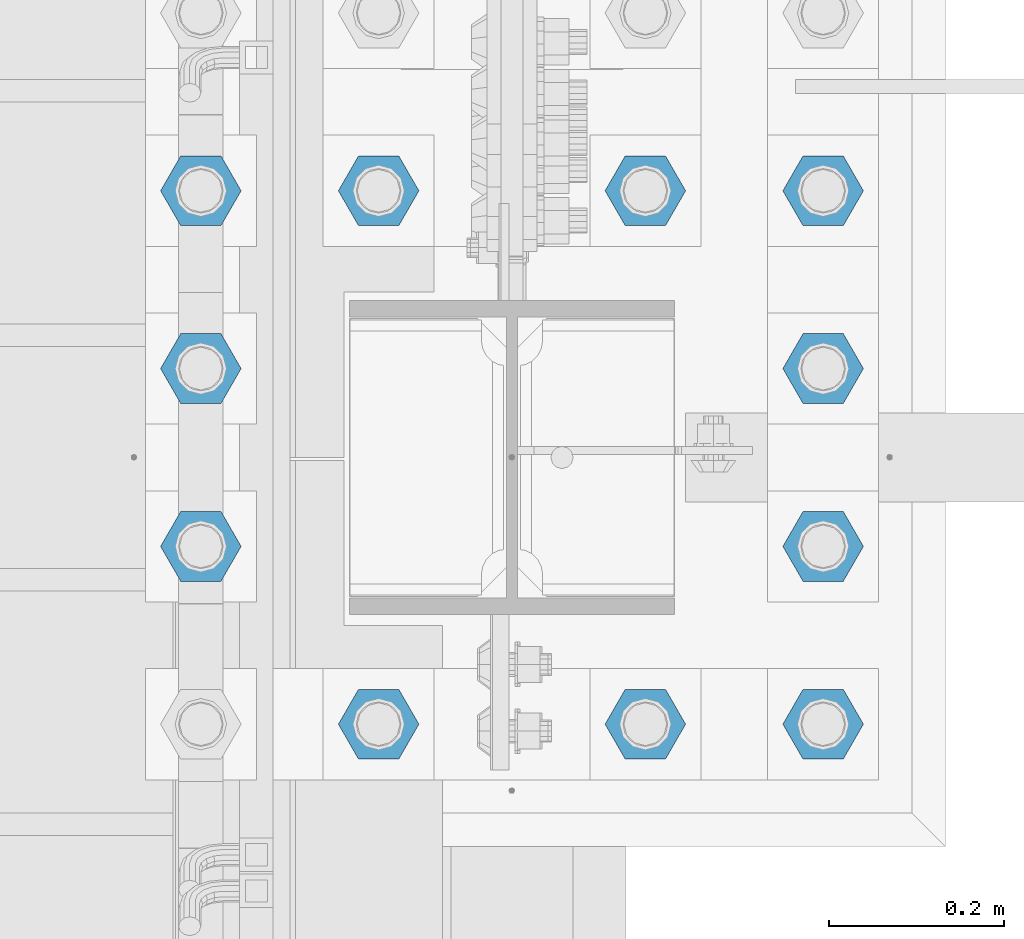
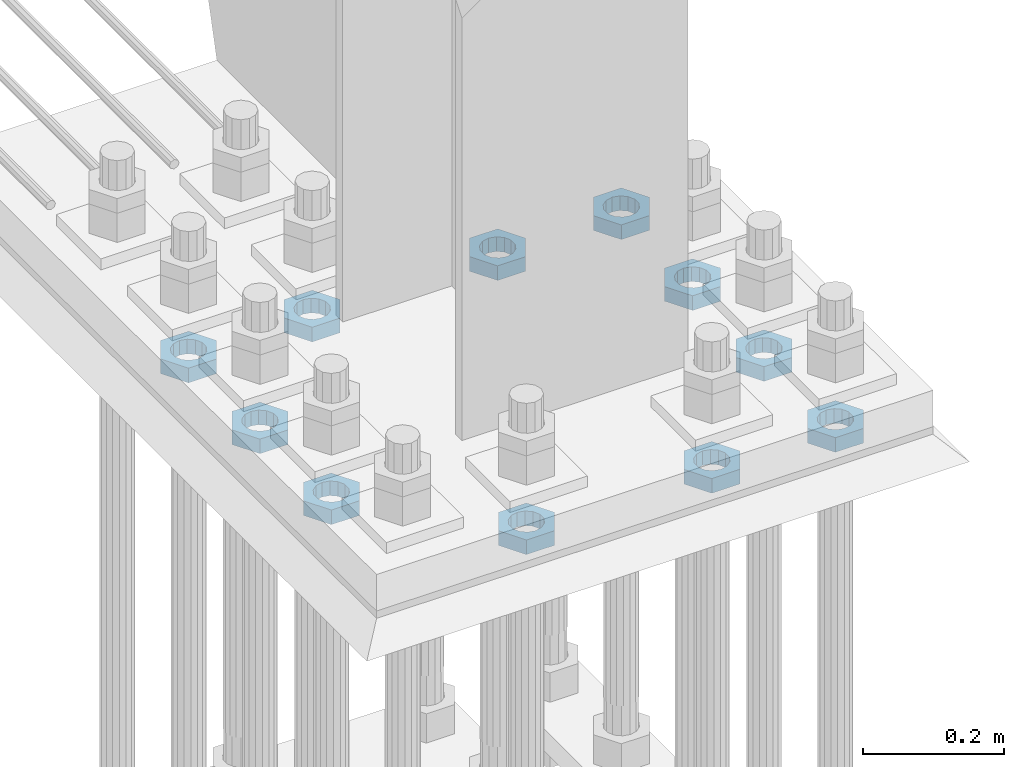
# One storey, part 2090 of 3843: 11 beams, 1 element without a shape of its own.
"""IFC2X3 building model written with IfcOpenShell, lengths in millimetres."""

from ifc_helpers import new_model, si_unit, frame, origin_with_axes, place, context, subcontext, project, spatial, faceted_brep, material, type_object, element, aggregate, save


model = new_model("IFC2X3")

# Units and contexts
model_context = context("Model", 3, precision=1e-05, world=origin_with_axes())
body_context = subcontext(model_context, "Body", "Model", "MODEL_VIEW")
ifc_project = project(units=[si_unit("LENGTHUNIT", "METRE", prefix="MILLI"), si_unit("AREAUNIT", "SQUARE_METRE"), si_unit("VOLUMEUNIT", "CUBIC_METRE"), si_unit("MASSUNIT", "GRAM", prefix="KILO"), si_unit("TIMEUNIT", "SECOND"), si_unit("PLANEANGLEUNIT", "RADIAN"), si_unit("SOLIDANGLEUNIT", "STERADIAN"), si_unit("THERMODYNAMICTEMPERATUREUNIT", "DEGREE_CELSIUS"), si_unit("LUMINOUSINTENSITYUNIT", "LUMEN")], contexts=[model_context])

# Site, building, storey
site_placement = place(None, origin_with_axes())
site = spatial("IfcSite", under=ifc_project, at=site_placement, CompositionType="ELEMENT")
building_placement = place(site_placement, origin_with_axes())
building = spatial("IfcBuilding", under=site, at=building_placement, Name="Undefined", CompositionType="ELEMENT")
storey_placement = place(building_placement, origin_with_axes())
storey = spatial("IfcBuildingStorey", under=building, at=storey_placement, Name="Undefined", CompositionType="ELEMENT", Elevation=0.0)

# Assembly, beams
assembly_placement = place(storey_placement, origin_with_axes())
assembly = element("IfcElementAssembly", 1, at=assembly_placement, inside=storey, Name="TEMPLATE", AssemblyPlace="NOTDEFINED", PredefinedType="RIGID_FRAME")
ifc_material = material(Name="STEEL/A572-50")
beam_type = type_object("IfcBeamType", Name="2_HALF_NUT", PredefinedType="NOTDEFINED")
beam_1_placement = place(assembly_placement, frame((55575.2, 20205.7, 29603.7), z_axis=(0.0, -1.0, 0.0), x_axis=(0.0, 0.0, -1.0)))
beam_1 = element("IfcBeam", 2, at=beam_1_placement, type_object=beam_type, material=ifc_material, Name="NUT", ObjectType="2_HALF_NUT", context=body_context, shape_type="Brep", body=[
    faceted_brep([(0.0, -46.0369987487793, 0.0), (0.0, -23.0184993743896, -39.869213104248), (25.4000000000015, -23.0184993743896, -39.869213104248), (25.4000000000015, -46.0369987487793, 0.0), (0.0, 23.0184993743896, -39.869213104248), (25.4000000000015, 23.0184993743896, -39.869213104248), (0.0, 46.0369987487793, 0.0), (25.4000000000015, 46.0369987487793, 0.0), (0.0, 23.0184993743896, 39.869213104248), (25.4000000000015, 23.0184993743896, 39.869213104248), (0.0, -23.0184993743896, 39.869213104248), (25.4000000000015, -23.0184993743896, 39.869213104248), (0.0, 0.0, 26.1940002441406), (0.0, 11.3650617044477, 23.5999013092805), (25.4000000000015, 11.3650617044477, 23.5999013092805), (25.4000000000015, 0.0, 26.1940002441406), (0.0, 20.4791109456419, 16.3316083006721), (25.4000000000015, 20.4791109456419, 16.3316083006721), (0.0, 25.5370200498292, 5.82867859874386), (25.4000000000015, 25.5370200498292, 5.82867859874386), (0.0, 25.5370200498292, -5.82867859874386), (25.4000000000015, 25.5370200498292, -5.82867859874386), (0.0, 20.4791109456419, -16.3316083006721), (25.4000000000015, 20.4791109456419, -16.3316083006721), (0.0, 11.3650617044477, -23.5999013092805), (25.4000000000015, 11.3650617044477, -23.5999013092805), (0.0, 0.0, -26.1940002441406), (25.4000000000015, 0.0, -26.1940002441406), (0.0, -11.3650617044477, -23.5999013092805), (25.4000000000015, -11.3650617044477, -23.5999013092805), (0.0, -20.4791109456419, -16.3316083006721), (25.4000000000015, -20.4791109456419, -16.3316083006721), (0.0, -25.5370200498292, -5.82867859874386), (25.4000000000015, -25.5370200498292, -5.82867859874386), (0.0, -25.5370200498292, 5.82867859874386), (25.4000000000015, -25.5370200498292, 5.82867859874386), (0.0, -20.4791109456419, 16.3316083006721), (25.4000000000015, -20.4791109456419, 16.3316083006721), (0.0, -11.3650617044477, 23.5999013092805), (25.4000000000015, -11.3650617044477, 23.5999013092805)], [[[0, 1, 2, 3]], [[1, 4, 5, 2]], [[4, 6, 7, 5]], [[6, 8, 9, 7]], [[8, 10, 11, 9]], [[10, 0, 3, 11]], [[12, 13, 14, 15]], [[13, 16, 17, 14]], [[16, 18, 19, 17]], [[18, 20, 21, 19]], [[20, 22, 23, 21]], [[22, 24, 25, 23]], [[24, 26, 27, 25]], [[26, 28, 29, 27]], [[28, 30, 31, 29]], [[30, 32, 33, 31]], [[32, 34, 35, 33]], [[34, 36, 37, 35]], [[36, 38, 39, 37]], [[38, 12, 15, 39]], [[5, 7, 9, 11, 3, 2], [17, 19, 21, 23, 25, 27, 29, 31, 33, 35, 37, 39, 15, 14]], [[10, 8, 6, 4, 1, 0], [38, 36, 34, 32, 30, 28, 26, 24, 22, 20, 18, 16, 13, 12]]]),
])
beam_2_placement = place(assembly_placement, frame((55575.2, 20408.9, 29603.7), z_axis=(0.0, -1.0, 0.0), x_axis=(0.0, 0.0, -1.0)))
beam_2 = element("IfcBeam", 3, at=beam_2_placement, type_object=beam_type, material=ifc_material, Name="NUT", ObjectType="2_HALF_NUT", context=body_context, shape_type="Brep", body=[
    faceted_brep([(0.0, -46.0369987487793, 0.0), (0.0, -23.0184993743896, -39.869213104248), (25.4000000000015, -23.0184993743896, -39.869213104248), (25.4000000000015, -46.0369987487793, 0.0), (0.0, 23.0184993743896, -39.869213104248), (25.4000000000015, 23.0184993743896, -39.869213104248), (0.0, 46.0369987487793, 0.0), (25.4000000000015, 46.0369987487793, 0.0), (0.0, 23.0184993743896, 39.869213104248), (25.4000000000015, 23.0184993743896, 39.869213104248), (0.0, -23.0184993743896, 39.869213104248), (25.4000000000015, -23.0184993743896, 39.869213104248), (0.0, 0.0, 26.1940002441406), (0.0, 11.3650617044477, 23.5999013092805), (25.4000000000015, 11.3650617044477, 23.5999013092805), (25.4000000000015, 0.0, 26.1940002441406), (0.0, 20.4791109456419, 16.3316083006721), (25.4000000000015, 20.4791109456419, 16.3316083006721), (0.0, 25.5370200498292, 5.82867859874386), (25.4000000000015, 25.5370200498292, 5.82867859874386), (0.0, 25.5370200498292, -5.82867859874386), (25.4000000000015, 25.5370200498292, -5.82867859874386), (0.0, 20.4791109456419, -16.3316083006721), (25.4000000000015, 20.4791109456419, -16.3316083006721), (0.0, 11.3650617044477, -23.5999013092805), (25.4000000000015, 11.3650617044477, -23.5999013092805), (0.0, 0.0, -26.1940002441406), (25.4000000000015, 0.0, -26.1940002441406), (0.0, -11.3650617044477, -23.5999013092805), (25.4000000000015, -11.3650617044477, -23.5999013092805), (0.0, -20.4791109456419, -16.3316083006721), (25.4000000000015, -20.4791109456419, -16.3316083006721), (0.0, -25.5370200498292, -5.82867859874386), (25.4000000000015, -25.5370200498292, -5.82867859874386), (0.0, -25.5370200498292, 5.82867859874386), (25.4000000000015, -25.5370200498292, 5.82867859874386), (0.0, -20.4791109456419, 16.3316083006721), (25.4000000000015, -20.4791109456419, 16.3316083006721), (0.0, -11.3650617044477, 23.5999013092805), (25.4000000000015, -11.3650617044477, 23.5999013092805)], [[[0, 1, 2, 3]], [[1, 4, 5, 2]], [[4, 6, 7, 5]], [[6, 8, 9, 7]], [[8, 10, 11, 9]], [[10, 0, 3, 11]], [[12, 13, 14, 15]], [[13, 16, 17, 14]], [[16, 18, 19, 17]], [[18, 20, 21, 19]], [[20, 22, 23, 21]], [[22, 24, 25, 23]], [[24, 26, 27, 25]], [[26, 28, 29, 27]], [[28, 30, 31, 29]], [[30, 32, 33, 31]], [[32, 34, 35, 33]], [[34, 36, 37, 35]], [[36, 38, 39, 37]], [[38, 12, 15, 39]], [[5, 7, 9, 11, 3, 2], [17, 19, 21, 23, 25, 27, 29, 31, 33, 35, 37, 39, 15, 14]], [[10, 8, 6, 4, 1, 0], [38, 36, 34, 32, 30, 28, 26, 24, 22, 20, 18, 16, 13, 12]]]),
])
beam_3_placement = place(assembly_placement, frame((55778.4, 20612.1, 29603.7), z_axis=(0.0, -1.0, 0.0), x_axis=(0.0, 0.0, -1.0)))
beam_3 = element("IfcBeam", 4, at=beam_3_placement, type_object=beam_type, material=ifc_material, Name="NUT", ObjectType="2_HALF_NUT", context=body_context, shape_type="Brep", body=[
    faceted_brep([(0.0, -46.0369987487793, 0.0), (0.0, -23.0184993743896, -39.869213104248), (25.4000000000015, -23.0184993743896, -39.869213104248), (25.4000000000015, -46.0369987487793, 0.0), (0.0, 23.0184993743896, -39.869213104248), (25.4000000000015, 23.0184993743896, -39.869213104248), (0.0, 46.0369987487793, 0.0), (25.4000000000015, 46.0369987487793, 0.0), (0.0, 23.0184993743896, 39.869213104248), (25.4000000000015, 23.0184993743896, 39.869213104248), (0.0, -23.0184993743896, 39.869213104248), (25.4000000000015, -23.0184993743896, 39.869213104248), (0.0, 0.0, 26.1940002441406), (0.0, 11.3650617044477, 23.5999013092805), (25.4000000000015, 11.3650617044477, 23.5999013092805), (25.4000000000015, 0.0, 26.1940002441406), (0.0, 20.4791109456419, 16.3316083006721), (25.4000000000015, 20.4791109456419, 16.3316083006721), (0.0, 25.5370200498292, 5.82867859874386), (25.4000000000015, 25.5370200498292, 5.82867859874386), (0.0, 25.5370200498292, -5.82867859874386), (25.4000000000015, 25.5370200498292, -5.82867859874386), (0.0, 20.4791109456419, -16.3316083006721), (25.4000000000015, 20.4791109456419, -16.3316083006721), (0.0, 11.3650617044477, -23.5999013092805), (25.4000000000015, 11.3650617044477, -23.5999013092805), (0.0, 0.0, -26.1940002441406), (25.4000000000015, 0.0, -26.1940002441406), (0.0, -11.3650617044477, -23.5999013092805), (25.4000000000015, -11.3650617044477, -23.5999013092805), (0.0, -20.4791109456419, -16.3316083006721), (25.4000000000015, -20.4791109456419, -16.3316083006721), (0.0, -25.5370200498292, -5.82867859874386), (25.4000000000015, -25.5370200498292, -5.82867859874386), (0.0, -25.5370200498292, 5.82867859874386), (25.4000000000015, -25.5370200498292, 5.82867859874386), (0.0, -20.4791109456419, 16.3316083006721), (25.4000000000015, -20.4791109456419, 16.3316083006721), (0.0, -11.3650617044477, 23.5999013092805), (25.4000000000015, -11.3650617044477, 23.5999013092805)], [[[0, 1, 2, 3]], [[1, 4, 5, 2]], [[4, 6, 7, 5]], [[6, 8, 9, 7]], [[8, 10, 11, 9]], [[10, 0, 3, 11]], [[12, 13, 14, 15]], [[13, 16, 17, 14]], [[16, 18, 19, 17]], [[18, 20, 21, 19]], [[20, 22, 23, 21]], [[22, 24, 25, 23]], [[24, 26, 27, 25]], [[26, 28, 29, 27]], [[28, 30, 31, 29]], [[30, 32, 33, 31]], [[32, 34, 35, 33]], [[34, 36, 37, 35]], [[36, 38, 39, 37]], [[38, 12, 15, 39]], [[5, 7, 9, 11, 3, 2], [17, 19, 21, 23, 25, 27, 29, 31, 33, 35, 37, 39, 15, 14]], [[10, 8, 6, 4, 1, 0], [38, 36, 34, 32, 30, 28, 26, 24, 22, 20, 18, 16, 13, 12]]]),
])
beam_4_placement = place(assembly_placement, frame((55575.2, 20612.1, 29603.7), z_axis=(0.0, -1.0, 0.0), x_axis=(0.0, 0.0, -1.0)))
beam_4 = element("IfcBeam", 5, at=beam_4_placement, type_object=beam_type, material=ifc_material, Name="NUT", ObjectType="2_HALF_NUT", context=body_context, shape_type="Brep", body=[
    faceted_brep([(0.0, -46.0369987487793, 0.0), (0.0, -23.0184993743896, -39.869213104248), (25.4000000000015, -23.0184993743896, -39.869213104248), (25.4000000000015, -46.0369987487793, 0.0), (0.0, 23.0184993743896, -39.869213104248), (25.4000000000015, 23.0184993743896, -39.869213104248), (0.0, 46.0369987487793, 0.0), (25.4000000000015, 46.0369987487793, 0.0), (0.0, 23.0184993743896, 39.869213104248), (25.4000000000015, 23.0184993743896, 39.869213104248), (0.0, -23.0184993743896, 39.869213104248), (25.4000000000015, -23.0184993743896, 39.869213104248), (0.0, 0.0, 26.1940002441406), (0.0, 11.3650617044477, 23.5999013092805), (25.4000000000015, 11.3650617044477, 23.5999013092805), (25.4000000000015, 0.0, 26.1940002441406), (0.0, 20.4791109456419, 16.3316083006721), (25.4000000000015, 20.4791109456419, 16.3316083006721), (0.0, 25.5370200498292, 5.82867859874386), (25.4000000000015, 25.5370200498292, 5.82867859874386), (0.0, 25.5370200498292, -5.82867859874386), (25.4000000000015, 25.5370200498292, -5.82867859874386), (0.0, 20.4791109456419, -16.3316083006721), (25.4000000000015, 20.4791109456419, -16.3316083006721), (0.0, 11.3650617044477, -23.5999013092805), (25.4000000000015, 11.3650617044477, -23.5999013092805), (0.0, 0.0, -26.1940002441406), (25.4000000000015, 0.0, -26.1940002441406), (0.0, -11.3650617044477, -23.5999013092805), (25.4000000000015, -11.3650617044477, -23.5999013092805), (0.0, -20.4791109456419, -16.3316083006721), (25.4000000000015, -20.4791109456419, -16.3316083006721), (0.0, -25.5370200498292, -5.82867859874386), (25.4000000000015, -25.5370200498292, -5.82867859874386), (0.0, -25.5370200498292, 5.82867859874386), (25.4000000000015, -25.5370200498292, 5.82867859874386), (0.0, -20.4791109456419, 16.3316083006721), (25.4000000000015, -20.4791109456419, 16.3316083006721), (0.0, -11.3650617044477, 23.5999013092805), (25.4000000000015, -11.3650617044477, 23.5999013092805)], [[[0, 1, 2, 3]], [[1, 4, 5, 2]], [[4, 6, 7, 5]], [[6, 8, 9, 7]], [[8, 10, 11, 9]], [[10, 0, 3, 11]], [[12, 13, 14, 15]], [[13, 16, 17, 14]], [[16, 18, 19, 17]], [[18, 20, 21, 19]], [[20, 22, 23, 21]], [[22, 24, 25, 23]], [[24, 26, 27, 25]], [[26, 28, 29, 27]], [[28, 30, 31, 29]], [[30, 32, 33, 31]], [[32, 34, 35, 33]], [[34, 36, 37, 35]], [[36, 38, 39, 37]], [[38, 12, 15, 39]], [[5, 7, 9, 11, 3, 2], [17, 19, 21, 23, 25, 27, 29, 31, 33, 35, 37, 39, 15, 14]], [[10, 8, 6, 4, 1, 0], [38, 36, 34, 32, 30, 28, 26, 24, 22, 20, 18, 16, 13, 12]]]),
])
beam_5_placement = place(assembly_placement, frame((56083.2, 20612.1, 29603.7), z_axis=(0.0, 1.0, 0.0), x_axis=(0.0, 0.0, -1.0)))
beam_5 = element("IfcBeam", 6, at=beam_5_placement, type_object=beam_type, material=ifc_material, Name="NUT", ObjectType="2_HALF_NUT", context=body_context, shape_type="Brep", body=[
    faceted_brep([(0.0, -46.0369987487793, 0.0), (0.0, -23.0184993743896, -39.869213104248), (25.4000000000015, -23.0184993743896, -39.869213104248), (25.4000000000015, -46.0369987487793, 0.0), (0.0, 23.0184993743896, -39.869213104248), (25.4000000000015, 23.0184993743896, -39.869213104248), (0.0, 46.0369987487793, 0.0), (25.4000000000015, 46.0369987487793, 0.0), (0.0, 23.0184993743896, 39.869213104248), (25.4000000000015, 23.0184993743896, 39.869213104248), (0.0, -23.0184993743896, 39.869213104248), (25.4000000000015, -23.0184993743896, 39.869213104248), (0.0, 0.0, 26.1940002441406), (0.0, 11.3650617044477, 23.5999013092805), (25.4000000000015, 11.3650617044477, 23.5999013092805), (25.4000000000015, 0.0, 26.1940002441406), (0.0, 20.4791109456419, 16.3316083006721), (25.4000000000015, 20.4791109456419, 16.3316083006721), (0.0, 25.5370200498292, 5.82867859874386), (25.4000000000015, 25.5370200498292, 5.82867859874386), (0.0, 25.5370200498292, -5.82867859874386), (25.4000000000015, 25.5370200498292, -5.82867859874386), (0.0, 20.4791109456419, -16.3316083006721), (25.4000000000015, 20.4791109456419, -16.3316083006721), (0.0, 11.3650617044477, -23.5999013092805), (25.4000000000015, 11.3650617044477, -23.5999013092805), (0.0, 0.0, -26.1940002441406), (25.4000000000015, 0.0, -26.1940002441406), (0.0, -11.3650617044477, -23.5999013092805), (25.4000000000015, -11.3650617044477, -23.5999013092805), (0.0, -20.4791109456419, -16.3316083006721), (25.4000000000015, -20.4791109456419, -16.3316083006721), (0.0, -25.5370200498292, -5.82867859874386), (25.4000000000015, -25.5370200498292, -5.82867859874386), (0.0, -25.5370200498292, 5.82867859874386), (25.4000000000015, -25.5370200498292, 5.82867859874386), (0.0, -20.4791109456419, 16.3316083006721), (25.4000000000015, -20.4791109456419, 16.3316083006721), (0.0, -11.3650617044477, 23.5999013092805), (25.4000000000015, -11.3650617044477, 23.5999013092805)], [[[0, 1, 2, 3]], [[1, 4, 5, 2]], [[4, 6, 7, 5]], [[6, 8, 9, 7]], [[8, 10, 11, 9]], [[10, 0, 3, 11]], [[12, 13, 14, 15]], [[13, 16, 17, 14]], [[16, 18, 19, 17]], [[18, 20, 21, 19]], [[20, 22, 23, 21]], [[22, 24, 25, 23]], [[24, 26, 27, 25]], [[26, 28, 29, 27]], [[28, 30, 31, 29]], [[30, 32, 33, 31]], [[32, 34, 35, 33]], [[34, 36, 37, 35]], [[36, 38, 39, 37]], [[38, 12, 15, 39]], [[5, 7, 9, 11, 3, 2], [17, 19, 21, 23, 25, 27, 29, 31, 33, 35, 37, 39, 15, 14]], [[10, 8, 6, 4, 1, 0], [38, 36, 34, 32, 30, 28, 26, 24, 22, 20, 18, 16, 13, 12]]]),
])
beam_6_placement = place(assembly_placement, frame((56286.4, 20612.1, 29603.7), z_axis=(0.0, 1.0, 0.0), x_axis=(0.0, 0.0, -1.0)))
beam_6 = element("IfcBeam", 7, at=beam_6_placement, type_object=beam_type, material=ifc_material, Name="NUT", ObjectType="2_HALF_NUT", context=body_context, shape_type="Brep", body=[
    faceted_brep([(0.0, -46.0369987487793, 0.0), (0.0, -23.0184993743896, -39.869213104248), (25.4000000000015, -23.0184993743896, -39.869213104248), (25.4000000000015, -46.0369987487793, 0.0), (0.0, 23.0184993743896, -39.869213104248), (25.4000000000015, 23.0184993743896, -39.869213104248), (0.0, 46.0369987487793, 0.0), (25.4000000000015, 46.0369987487793, 0.0), (0.0, 23.0184993743896, 39.869213104248), (25.4000000000015, 23.0184993743896, 39.869213104248), (0.0, -23.0184993743896, 39.869213104248), (25.4000000000015, -23.0184993743896, 39.869213104248), (0.0, 0.0, 26.1940002441406), (0.0, 11.3650617044477, 23.5999013092805), (25.4000000000015, 11.3650617044477, 23.5999013092805), (25.4000000000015, 0.0, 26.1940002441406), (0.0, 20.4791109456419, 16.3316083006721), (25.4000000000015, 20.4791109456419, 16.3316083006721), (0.0, 25.5370200498292, 5.82867859874386), (25.4000000000015, 25.5370200498292, 5.82867859874386), (0.0, 25.5370200498292, -5.82867859874386), (25.4000000000015, 25.5370200498292, -5.82867859874386), (0.0, 20.4791109456419, -16.3316083006721), (25.4000000000015, 20.4791109456419, -16.3316083006721), (0.0, 11.3650617044477, -23.5999013092805), (25.4000000000015, 11.3650617044477, -23.5999013092805), (0.0, 0.0, -26.1940002441406), (25.4000000000015, 0.0, -26.1940002441406), (0.0, -11.3650617044477, -23.5999013092805), (25.4000000000015, -11.3650617044477, -23.5999013092805), (0.0, -20.4791109456419, -16.3316083006721), (25.4000000000015, -20.4791109456419, -16.3316083006721), (0.0, -25.5370200498292, -5.82867859874386), (25.4000000000015, -25.5370200498292, -5.82867859874386), (0.0, -25.5370200498292, 5.82867859874386), (25.4000000000015, -25.5370200498292, 5.82867859874386), (0.0, -20.4791109456419, 16.3316083006721), (25.4000000000015, -20.4791109456419, 16.3316083006721), (0.0, -11.3650617044477, 23.5999013092805), (25.4000000000015, -11.3650617044477, 23.5999013092805)], [[[0, 1, 2, 3]], [[1, 4, 5, 2]], [[4, 6, 7, 5]], [[6, 8, 9, 7]], [[8, 10, 11, 9]], [[10, 0, 3, 11]], [[12, 13, 14, 15]], [[13, 16, 17, 14]], [[16, 18, 19, 17]], [[18, 20, 21, 19]], [[20, 22, 23, 21]], [[22, 24, 25, 23]], [[24, 26, 27, 25]], [[26, 28, 29, 27]], [[28, 30, 31, 29]], [[30, 32, 33, 31]], [[32, 34, 35, 33]], [[34, 36, 37, 35]], [[36, 38, 39, 37]], [[38, 12, 15, 39]], [[5, 7, 9, 11, 3, 2], [17, 19, 21, 23, 25, 27, 29, 31, 33, 35, 37, 39, 15, 14]], [[10, 8, 6, 4, 1, 0], [38, 36, 34, 32, 30, 28, 26, 24, 22, 20, 18, 16, 13, 12]]]),
])
beam_7_placement = place(assembly_placement, frame((56286.4, 20408.9, 29603.7), z_axis=(0.0, 1.0, 0.0), x_axis=(0.0, 0.0, -1.0)))
beam_7 = element("IfcBeam", 8, at=beam_7_placement, type_object=beam_type, material=ifc_material, Name="NUT", ObjectType="2_HALF_NUT", context=body_context, shape_type="Brep", body=[
    faceted_brep([(0.0, -46.0369987487793, 0.0), (0.0, -23.0184993743896, -39.869213104248), (25.4000000000015, -23.0184993743896, -39.869213104248), (25.4000000000015, -46.0369987487793, 0.0), (0.0, 23.0184993743896, -39.869213104248), (25.4000000000015, 23.0184993743896, -39.869213104248), (0.0, 46.0369987487793, 0.0), (25.4000000000015, 46.0369987487793, 0.0), (0.0, 23.0184993743896, 39.869213104248), (25.4000000000015, 23.0184993743896, 39.869213104248), (0.0, -23.0184993743896, 39.869213104248), (25.4000000000015, -23.0184993743896, 39.869213104248), (0.0, 0.0, 26.1940002441406), (0.0, 11.3650617044477, 23.5999013092805), (25.4000000000015, 11.3650617044477, 23.5999013092805), (25.4000000000015, 0.0, 26.1940002441406), (0.0, 20.4791109456419, 16.3316083006721), (25.4000000000015, 20.4791109456419, 16.3316083006721), (0.0, 25.5370200498292, 5.82867859874386), (25.4000000000015, 25.5370200498292, 5.82867859874386), (0.0, 25.5370200498292, -5.82867859874386), (25.4000000000015, 25.5370200498292, -5.82867859874386), (0.0, 20.4791109456419, -16.3316083006721), (25.4000000000015, 20.4791109456419, -16.3316083006721), (0.0, 11.3650617044477, -23.5999013092805), (25.4000000000015, 11.3650617044477, -23.5999013092805), (0.0, 0.0, -26.1940002441406), (25.4000000000015, 0.0, -26.1940002441406), (0.0, -11.3650617044477, -23.5999013092805), (25.4000000000015, -11.3650617044477, -23.5999013092805), (0.0, -20.4791109456419, -16.3316083006721), (25.4000000000015, -20.4791109456419, -16.3316083006721), (0.0, -25.5370200498292, -5.82867859874386), (25.4000000000015, -25.5370200498292, -5.82867859874386), (0.0, -25.5370200498292, 5.82867859874386), (25.4000000000015, -25.5370200498292, 5.82867859874386), (0.0, -20.4791109456419, 16.3316083006721), (25.4000000000015, -20.4791109456419, 16.3316083006721), (0.0, -11.3650617044477, 23.5999013092805), (25.4000000000015, -11.3650617044477, 23.5999013092805)], [[[0, 1, 2, 3]], [[1, 4, 5, 2]], [[4, 6, 7, 5]], [[6, 8, 9, 7]], [[8, 10, 11, 9]], [[10, 0, 3, 11]], [[12, 13, 14, 15]], [[13, 16, 17, 14]], [[16, 18, 19, 17]], [[18, 20, 21, 19]], [[20, 22, 23, 21]], [[22, 24, 25, 23]], [[24, 26, 27, 25]], [[26, 28, 29, 27]], [[28, 30, 31, 29]], [[30, 32, 33, 31]], [[32, 34, 35, 33]], [[34, 36, 37, 35]], [[36, 38, 39, 37]], [[38, 12, 15, 39]], [[5, 7, 9, 11, 3, 2], [17, 19, 21, 23, 25, 27, 29, 31, 33, 35, 37, 39, 15, 14]], [[10, 8, 6, 4, 1, 0], [38, 36, 34, 32, 30, 28, 26, 24, 22, 20, 18, 16, 13, 12]]]),
])
beam_8_placement = place(assembly_placement, frame((56286.4, 20205.7, 29603.7), z_axis=(0.0, 1.0, 0.0), x_axis=(0.0, 0.0, -1.0)))
beam_8 = element("IfcBeam", 9, at=beam_8_placement, type_object=beam_type, material=ifc_material, Name="NUT", ObjectType="2_HALF_NUT", context=body_context, shape_type="Brep", body=[
    faceted_brep([(0.0, -46.0369987487793, 0.0), (0.0, -23.0184993743896, -39.869213104248), (25.4000000000015, -23.0184993743896, -39.869213104248), (25.4000000000015, -46.0369987487793, 0.0), (0.0, 23.0184993743896, -39.869213104248), (25.4000000000015, 23.0184993743896, -39.869213104248), (0.0, 46.0369987487793, 0.0), (25.4000000000015, 46.0369987487793, 0.0), (0.0, 23.0184993743896, 39.869213104248), (25.4000000000015, 23.0184993743896, 39.869213104248), (0.0, -23.0184993743896, 39.869213104248), (25.4000000000015, -23.0184993743896, 39.869213104248), (0.0, 0.0, 26.1940002441406), (0.0, 11.3650617044477, 23.5999013092805), (25.4000000000015, 11.3650617044477, 23.5999013092805), (25.4000000000015, 0.0, 26.1940002441406), (0.0, 20.4791109456419, 16.3316083006721), (25.4000000000015, 20.4791109456419, 16.3316083006721), (0.0, 25.5370200498292, 5.82867859874386), (25.4000000000015, 25.5370200498292, 5.82867859874386), (0.0, 25.5370200498292, -5.82867859874386), (25.4000000000015, 25.5370200498292, -5.82867859874386), (0.0, 20.4791109456419, -16.3316083006721), (25.4000000000015, 20.4791109456419, -16.3316083006721), (0.0, 11.3650617044477, -23.5999013092805), (25.4000000000015, 11.3650617044477, -23.5999013092805), (0.0, 0.0, -26.1940002441406), (25.4000000000015, 0.0, -26.1940002441406), (0.0, -11.3650617044477, -23.5999013092805), (25.4000000000015, -11.3650617044477, -23.5999013092805), (0.0, -20.4791109456419, -16.3316083006721), (25.4000000000015, -20.4791109456419, -16.3316083006721), (0.0, -25.5370200498292, -5.82867859874386), (25.4000000000015, -25.5370200498292, -5.82867859874386), (0.0, -25.5370200498292, 5.82867859874386), (25.4000000000015, -25.5370200498292, 5.82867859874386), (0.0, -20.4791109456419, 16.3316083006721), (25.4000000000015, -20.4791109456419, 16.3316083006721), (0.0, -11.3650617044477, 23.5999013092805), (25.4000000000015, -11.3650617044477, 23.5999013092805)], [[[0, 1, 2, 3]], [[1, 4, 5, 2]], [[4, 6, 7, 5]], [[6, 8, 9, 7]], [[8, 10, 11, 9]], [[10, 0, 3, 11]], [[12, 13, 14, 15]], [[13, 16, 17, 14]], [[16, 18, 19, 17]], [[18, 20, 21, 19]], [[20, 22, 23, 21]], [[22, 24, 25, 23]], [[24, 26, 27, 25]], [[26, 28, 29, 27]], [[28, 30, 31, 29]], [[30, 32, 33, 31]], [[32, 34, 35, 33]], [[34, 36, 37, 35]], [[36, 38, 39, 37]], [[38, 12, 15, 39]], [[5, 7, 9, 11, 3, 2], [17, 19, 21, 23, 25, 27, 29, 31, 33, 35, 37, 39, 15, 14]], [[10, 8, 6, 4, 1, 0], [38, 36, 34, 32, 30, 28, 26, 24, 22, 20, 18, 16, 13, 12]]]),
])
beam_9_placement = place(assembly_placement, frame((56286.4, 20002.5, 29603.7), z_axis=(0.0, 1.0, 0.0), x_axis=(0.0, 0.0, -1.0)))
beam_9 = element("IfcBeam", 10, at=beam_9_placement, type_object=beam_type, material=ifc_material, Name="NUT", ObjectType="2_HALF_NUT", context=body_context, shape_type="Brep", body=[
    faceted_brep([(0.0, -46.0369987487793, 0.0), (0.0, -23.0184993743896, -39.869213104248), (25.4000000000015, -23.0184993743896, -39.869213104248), (25.4000000000015, -46.0369987487793, 0.0), (0.0, 23.0184993743896, -39.869213104248), (25.4000000000015, 23.0184993743896, -39.869213104248), (0.0, 46.0369987487793, 0.0), (25.4000000000015, 46.0369987487793, 0.0), (0.0, 23.0184993743896, 39.869213104248), (25.4000000000015, 23.0184993743896, 39.869213104248), (0.0, -23.0184993743896, 39.869213104248), (25.4000000000015, -23.0184993743896, 39.869213104248), (0.0, 0.0, 26.1940002441406), (0.0, 11.3650617044477, 23.5999013092805), (25.4000000000015, 11.3650617044477, 23.5999013092805), (25.4000000000015, 0.0, 26.1940002441406), (0.0, 20.4791109456419, 16.3316083006721), (25.4000000000015, 20.4791109456419, 16.3316083006721), (0.0, 25.5370200498292, 5.82867859874386), (25.4000000000015, 25.5370200498292, 5.82867859874386), (0.0, 25.5370200498292, -5.82867859874386), (25.4000000000015, 25.5370200498292, -5.82867859874386), (0.0, 20.4791109456419, -16.3316083006721), (25.4000000000015, 20.4791109456419, -16.3316083006721), (0.0, 11.3650617044477, -23.5999013092805), (25.4000000000015, 11.3650617044477, -23.5999013092805), (0.0, 0.0, -26.1940002441406), (25.4000000000015, 0.0, -26.1940002441406), (0.0, -11.3650617044477, -23.5999013092805), (25.4000000000015, -11.3650617044477, -23.5999013092805), (0.0, -20.4791109456419, -16.3316083006721), (25.4000000000015, -20.4791109456419, -16.3316083006721), (0.0, -25.5370200498292, -5.82867859874386), (25.4000000000015, -25.5370200498292, -5.82867859874386), (0.0, -25.5370200498292, 5.82867859874386), (25.4000000000015, -25.5370200498292, 5.82867859874386), (0.0, -20.4791109456419, 16.3316083006721), (25.4000000000015, -20.4791109456419, 16.3316083006721), (0.0, -11.3650617044477, 23.5999013092805), (25.4000000000015, -11.3650617044477, 23.5999013092805)], [[[0, 1, 2, 3]], [[1, 4, 5, 2]], [[4, 6, 7, 5]], [[6, 8, 9, 7]], [[8, 10, 11, 9]], [[10, 0, 3, 11]], [[12, 13, 14, 15]], [[13, 16, 17, 14]], [[16, 18, 19, 17]], [[18, 20, 21, 19]], [[20, 22, 23, 21]], [[22, 24, 25, 23]], [[24, 26, 27, 25]], [[26, 28, 29, 27]], [[28, 30, 31, 29]], [[30, 32, 33, 31]], [[32, 34, 35, 33]], [[34, 36, 37, 35]], [[36, 38, 39, 37]], [[38, 12, 15, 39]], [[5, 7, 9, 11, 3, 2], [17, 19, 21, 23, 25, 27, 29, 31, 33, 35, 37, 39, 15, 14]], [[10, 8, 6, 4, 1, 0], [38, 36, 34, 32, 30, 28, 26, 24, 22, 20, 18, 16, 13, 12]]]),
])
beam_10_placement = place(assembly_placement, frame((56083.2, 20002.5, 29603.7), z_axis=(0.0, 1.0, 0.0), x_axis=(0.0, 0.0, -1.0)))
beam_10 = element("IfcBeam", 11, at=beam_10_placement, type_object=beam_type, material=ifc_material, Name="NUT", ObjectType="2_HALF_NUT", context=body_context, shape_type="Brep", body=[
    faceted_brep([(0.0, -46.0369987487793, 0.0), (0.0, -23.0184993743896, -39.869213104248), (25.4000000000015, -23.0184993743896, -39.869213104248), (25.4000000000015, -46.0369987487793, 0.0), (0.0, 23.0184993743896, -39.869213104248), (25.4000000000015, 23.0184993743896, -39.869213104248), (0.0, 46.0369987487793, 0.0), (25.4000000000015, 46.0369987487793, 0.0), (0.0, 23.0184993743896, 39.869213104248), (25.4000000000015, 23.0184993743896, 39.869213104248), (0.0, -23.0184993743896, 39.869213104248), (25.4000000000015, -23.0184993743896, 39.869213104248), (0.0, 0.0, 26.1940002441406), (0.0, 11.3650617044477, 23.5999013092805), (25.4000000000015, 11.3650617044477, 23.5999013092805), (25.4000000000015, 0.0, 26.1940002441406), (0.0, 20.4791109456419, 16.3316083006721), (25.4000000000015, 20.4791109456419, 16.3316083006721), (0.0, 25.5370200498292, 5.82867859874386), (25.4000000000015, 25.5370200498292, 5.82867859874386), (0.0, 25.5370200498292, -5.82867859874386), (25.4000000000015, 25.5370200498292, -5.82867859874386), (0.0, 20.4791109456419, -16.3316083006721), (25.4000000000015, 20.4791109456419, -16.3316083006721), (0.0, 11.3650617044477, -23.5999013092805), (25.4000000000015, 11.3650617044477, -23.5999013092805), (0.0, 0.0, -26.1940002441406), (25.4000000000015, 0.0, -26.1940002441406), (0.0, -11.3650617044477, -23.5999013092805), (25.4000000000015, -11.3650617044477, -23.5999013092805), (0.0, -20.4791109456419, -16.3316083006721), (25.4000000000015, -20.4791109456419, -16.3316083006721), (0.0, -25.5370200498292, -5.82867859874386), (25.4000000000015, -25.5370200498292, -5.82867859874386), (0.0, -25.5370200498292, 5.82867859874386), (25.4000000000015, -25.5370200498292, 5.82867859874386), (0.0, -20.4791109456419, 16.3316083006721), (25.4000000000015, -20.4791109456419, 16.3316083006721), (0.0, -11.3650617044477, 23.5999013092805), (25.4000000000015, -11.3650617044477, 23.5999013092805)], [[[0, 1, 2, 3]], [[1, 4, 5, 2]], [[4, 6, 7, 5]], [[6, 8, 9, 7]], [[8, 10, 11, 9]], [[10, 0, 3, 11]], [[12, 13, 14, 15]], [[13, 16, 17, 14]], [[16, 18, 19, 17]], [[18, 20, 21, 19]], [[20, 22, 23, 21]], [[22, 24, 25, 23]], [[24, 26, 27, 25]], [[26, 28, 29, 27]], [[28, 30, 31, 29]], [[30, 32, 33, 31]], [[32, 34, 35, 33]], [[34, 36, 37, 35]], [[36, 38, 39, 37]], [[38, 12, 15, 39]], [[5, 7, 9, 11, 3, 2], [17, 19, 21, 23, 25, 27, 29, 31, 33, 35, 37, 39, 15, 14]], [[10, 8, 6, 4, 1, 0], [38, 36, 34, 32, 30, 28, 26, 24, 22, 20, 18, 16, 13, 12]]]),
])
beam_11_placement = place(assembly_placement, frame((55778.4, 20002.5, 29603.7), z_axis=(0.0, -1.0, 0.0), x_axis=(0.0, 0.0, -1.0)))
beam_11 = element("IfcBeam", 12, at=beam_11_placement, type_object=beam_type, material=ifc_material, Name="NUT", ObjectType="2_HALF_NUT", context=body_context, shape_type="Brep", body=[
    faceted_brep([(0.0, -46.0369987487793, 0.0), (0.0, -23.0184993743896, -39.869213104248), (25.4000000000015, -23.0184993743896, -39.869213104248), (25.4000000000015, -46.0369987487793, 0.0), (0.0, 23.0184993743896, -39.869213104248), (25.4000000000015, 23.0184993743896, -39.869213104248), (0.0, 46.0369987487793, 0.0), (25.4000000000015, 46.0369987487793, 0.0), (0.0, 23.0184993743896, 39.869213104248), (25.4000000000015, 23.0184993743896, 39.869213104248), (0.0, -23.0184993743896, 39.869213104248), (25.4000000000015, -23.0184993743896, 39.869213104248), (0.0, 0.0, 26.1940002441406), (0.0, 11.3650617044477, 23.5999013092805), (25.4000000000015, 11.3650617044477, 23.5999013092805), (25.4000000000015, 0.0, 26.1940002441406), (0.0, 20.4791109456419, 16.3316083006721), (25.4000000000015, 20.4791109456419, 16.3316083006721), (0.0, 25.5370200498292, 5.82867859874386), (25.4000000000015, 25.5370200498292, 5.82867859874386), (0.0, 25.5370200498292, -5.82867859874386), (25.4000000000015, 25.5370200498292, -5.82867859874386), (0.0, 20.4791109456419, -16.3316083006721), (25.4000000000015, 20.4791109456419, -16.3316083006721), (0.0, 11.3650617044477, -23.5999013092805), (25.4000000000015, 11.3650617044477, -23.5999013092805), (0.0, 0.0, -26.1940002441406), (25.4000000000015, 0.0, -26.1940002441406), (0.0, -11.3650617044477, -23.5999013092805), (25.4000000000015, -11.3650617044477, -23.5999013092805), (0.0, -20.4791109456419, -16.3316083006721), (25.4000000000015, -20.4791109456419, -16.3316083006721), (0.0, -25.5370200498292, -5.82867859874386), (25.4000000000015, -25.5370200498292, -5.82867859874386), (0.0, -25.5370200498292, 5.82867859874386), (25.4000000000015, -25.5370200498292, 5.82867859874386), (0.0, -20.4791109456419, 16.3316083006721), (25.4000000000015, -20.4791109456419, 16.3316083006721), (0.0, -11.3650617044477, 23.5999013092805), (25.4000000000015, -11.3650617044477, 23.5999013092805)], [[[0, 1, 2, 3]], [[1, 4, 5, 2]], [[4, 6, 7, 5]], [[6, 8, 9, 7]], [[8, 10, 11, 9]], [[10, 0, 3, 11]], [[12, 13, 14, 15]], [[13, 16, 17, 14]], [[16, 18, 19, 17]], [[18, 20, 21, 19]], [[20, 22, 23, 21]], [[22, 24, 25, 23]], [[24, 26, 27, 25]], [[26, 28, 29, 27]], [[28, 30, 31, 29]], [[30, 32, 33, 31]], [[32, 34, 35, 33]], [[34, 36, 37, 35]], [[36, 38, 39, 37]], [[38, 12, 15, 39]], [[5, 7, 9, 11, 3, 2], [17, 19, 21, 23, 25, 27, 29, 31, 33, 35, 37, 39, 15, 14]], [[10, 8, 6, 4, 1, 0], [38, 36, 34, 32, 30, 28, 26, 24, 22, 20, 18, 16, 13, 12]]]),
])
aggregate(assembly, [beam_1, beam_2, beam_3, beam_4, beam_5, beam_6, beam_7, beam_8, beam_9, beam_10, beam_11])

save(model, "model.ifc")
